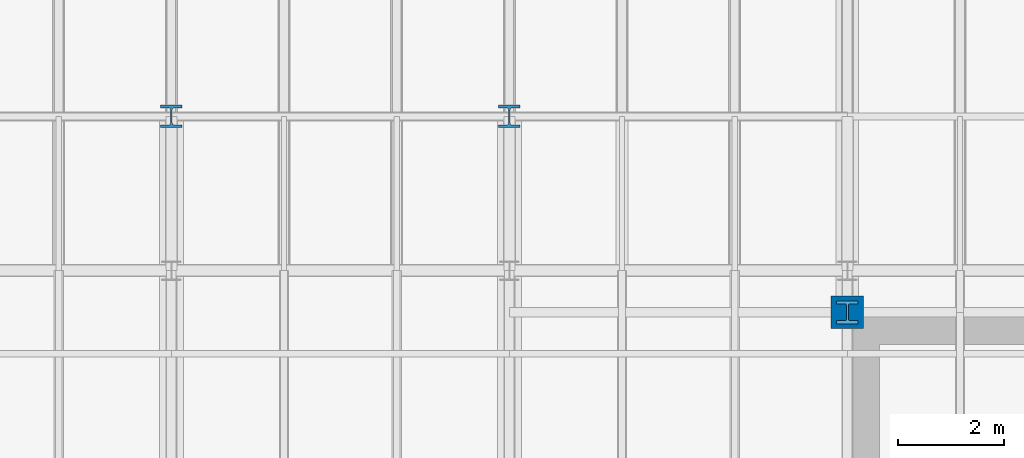
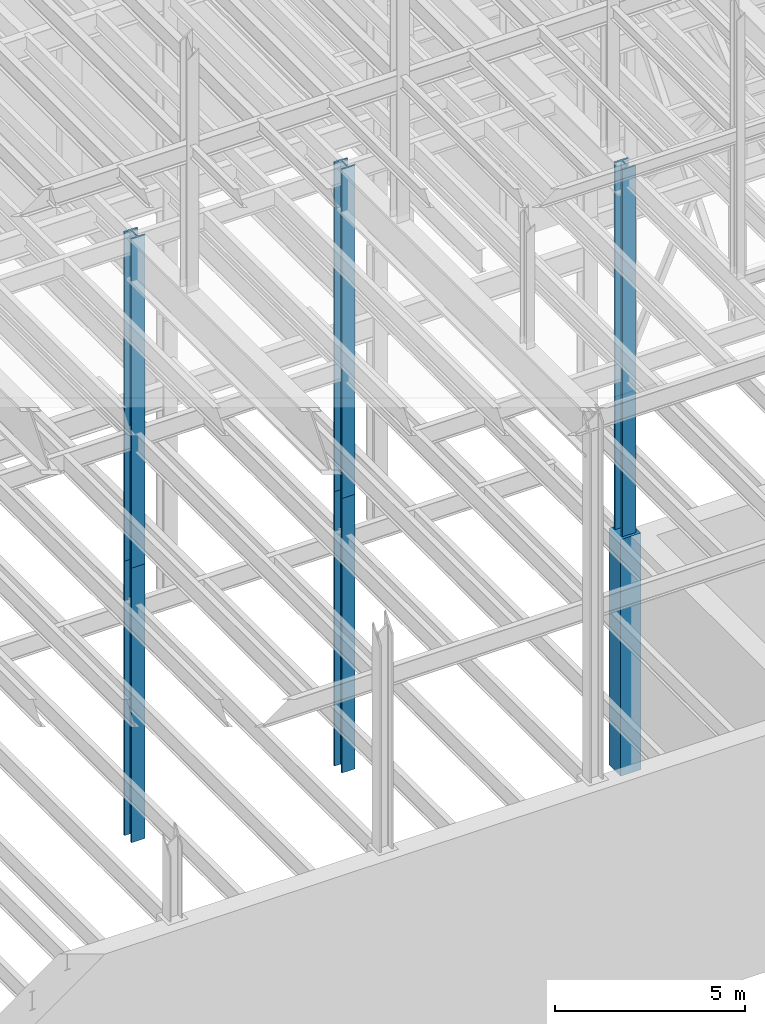
# One storey, part 27 of 150: 6 columns.
"""IFC2X3 building model written with IfcOpenShell, lengths in millimetres."""

from ifc_helpers import new_model, si_unit, frame, origin_with_axes, origin_2d_with_axis, place, context, subcontext, project, spatial, rectangle, i_section, extrude, material, type_object, element, save


model = new_model("IFC2X3")

# Units and contexts
model_context = context("Model", 3, precision=1e-05, world=origin_with_axes())
body_context = subcontext(model_context, "Body", "Model", "MODEL_VIEW")
ifc_project = project(units=[si_unit("LENGTHUNIT", "METRE", prefix="MILLI"), si_unit("AREAUNIT", "SQUARE_METRE"), si_unit("VOLUMEUNIT", "CUBIC_METRE"), si_unit("MASSUNIT", "GRAM", prefix="KILO"), si_unit("TIMEUNIT", "SECOND"), si_unit("PLANEANGLEUNIT", "RADIAN"), si_unit("SOLIDANGLEUNIT", "STERADIAN"), si_unit("THERMODYNAMICTEMPERATUREUNIT", "DEGREE_CELSIUS"), si_unit("LUMINOUSINTENSITYUNIT", "LUMEN")], contexts=[model_context])

# Site, building, storey
site_placement = place(None, origin_with_axes())
site = spatial("IfcSite", under=ifc_project, at=site_placement, CompositionType="ELEMENT")
building_placement = place(site_placement, origin_with_axes())
building = spatial("IfcBuilding", under=site, at=building_placement, Name="Undefined", CompositionType="ELEMENT")
storey_placement = place(building_placement, origin_with_axes())
storey = spatial("IfcBuildingStorey", under=building, at=storey_placement, Name="Undefined", CompositionType="ELEMENT", Elevation=0.0)

# Columns
ifc_material_1 = material(Name="STEEL/A992")
column_type_1 = type_object("IfcColumnType", Name="W14X311", PredefinedType="NOTDEFINED")
column_1_placement = place(storey_placement, frame((43789.6, 9398.0, 22707.6), z_axis=(0.0, 0.0, 1.0), x_axis=(1.0, 0.0, 0.0)))
element("IfcColumn", 1, at=column_1_placement, inside=storey, type_object=column_type_1, material=ifc_material_1, Name="COLUMN", ObjectType="W14X311", context=body_context, shape_type="SweptSolid", body=[
    extrude(i_section(OverallWidth=412.75, OverallDepth=434.975, WebThickness=36.5125, FlangeThickness=57.404, FilletRadius=33.0834, at=origin_2d_with_axis()), frame((0.0, 0.0, 12877.8), z_axis=(0.0, 0.0, -1.0), x_axis=(-1.0, 0.0, 0.0)), (0.0, 0.0, 1.0), 12877.8),
])
column_type_2 = type_object("IfcColumnType", Name="W14X283", PredefinedType="NOTDEFINED")
column_2_placement = place(storey_placement, frame((37388.8, 13106.4, 16154.4), z_axis=(0.0, 0.0, 1.0), x_axis=(1.0, 0.0, 0.0)))
element("IfcColumn", 2, at=column_2_placement, inside=storey, type_object=column_type_2, material=ifc_material_1, Name="COLUMN", ObjectType="W14X283", context=body_context, shape_type="SweptSolid", body=[
    extrude(i_section(OverallWidth=408.94, OverallDepth=425.45, WebThickness=33.3375, FlangeThickness=52.578, FilletRadius=33.1469, at=origin_2d_with_axis()), frame((0.0, 0.0, 8839.2), z_axis=(0.0, 0.0, -1.0), x_axis=(-1.0, 0.0, 0.0)), (0.0, 0.0, 1.0), 8839.20000000001),
])
column_3_placement = place(storey_placement, frame((37388.8, 13106.4, 24993.6), z_axis=(0.0, 0.0, 1.0), x_axis=(1.0, 0.0, 0.0)))
element("IfcColumn", 3, at=column_3_placement, inside=storey, type_object=column_type_2, material=ifc_material_1, Name="COLUMN", ObjectType="W14X283", context=body_context, shape_type="SweptSolid", body=[
    extrude(i_section(OverallWidth=408.94, OverallDepth=425.45, WebThickness=33.3375, FlangeThickness=52.578, FilletRadius=33.1469, at=origin_2d_with_axis()), frame((0.0, 0.0, 10591.8), z_axis=(0.0, 0.0, -1.0), x_axis=(-1.0, 0.0, 0.0)), (0.0, 0.0, 1.0), 10591.8),
])
column_4_placement = place(storey_placement, frame((30988.0, 13106.4, 16154.4), z_axis=(0.0, 0.0, 1.0), x_axis=(1.0, 0.0, 0.0)))
element("IfcColumn", 4, at=column_4_placement, inside=storey, type_object=column_type_2, material=ifc_material_1, Name="COLUMN", ObjectType="W14X283", context=body_context, shape_type="SweptSolid", body=[
    extrude(i_section(OverallWidth=408.94, OverallDepth=425.45, WebThickness=33.3375, FlangeThickness=52.578, FilletRadius=33.1469, at=origin_2d_with_axis()), frame((0.0, 0.0, 8839.2), z_axis=(0.0, 0.0, -1.0), x_axis=(-1.0, 0.0, 0.0)), (0.0, 0.0, 1.0), 8839.20000000001),
])
column_5_placement = place(storey_placement, frame((30988.0, 13106.4, 24993.6), z_axis=(0.0, 0.0, 1.0), x_axis=(1.0, 0.0, 0.0)))
element("IfcColumn", 5, at=column_5_placement, inside=storey, type_object=column_type_2, material=ifc_material_1, Name="COLUMN", ObjectType="W14X283", context=body_context, shape_type="SweptSolid", body=[
    extrude(i_section(OverallWidth=408.94, OverallDepth=425.45, WebThickness=33.3375, FlangeThickness=52.578, FilletRadius=33.1469, at=origin_2d_with_axis()), frame((0.0, 0.0, 10591.8), z_axis=(0.0, 0.0, -1.0), x_axis=(-1.0, 0.0, 0.0)), (0.0, 0.0, 1.0), 10591.8),
])
ifc_material_2 = material(Name="CONCRETE/5000")
column_type_3 = type_object("IfcColumnType", PredefinedType="NOTDEFINED")
column_6_placement = place(storey_placement, frame((43789.6, 9398.0, 16154.4), z_axis=(0.0, 0.0, 1.0), x_axis=(1.0, 0.0, 0.0)))
element("IfcColumn", 6, at=column_6_placement, inside=storey, type_object=column_type_3, material=ifc_material_2, Name="COLUMN", context=body_context, shape_type="SweptSolid", body=[
    extrude(rectangle(XDim=609.6, YDim=609.6, at=origin_2d_with_axis()), frame((0.0, 0.0, 7620.0), z_axis=(0.0, 0.0, -1.0), x_axis=(0.0, -1.0, 0.0)), (0.0, 0.0, 1.0), 7620.0),
])

save(model, "model.ifc")
